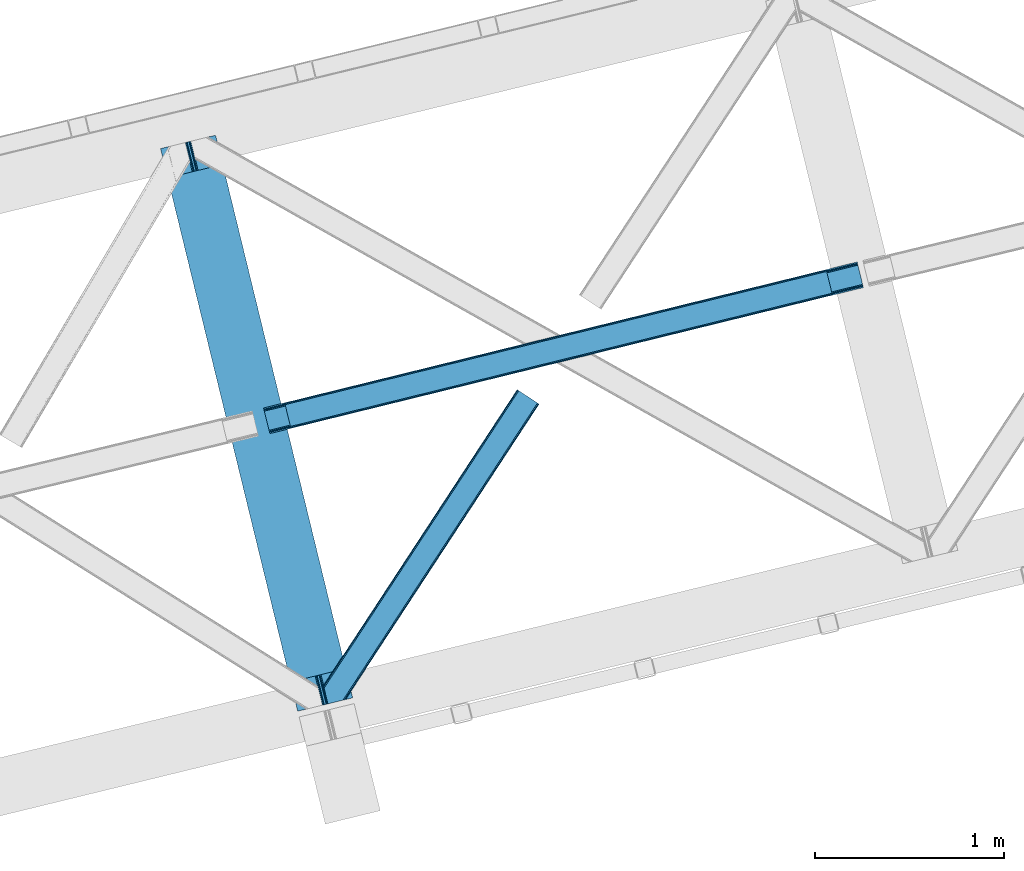
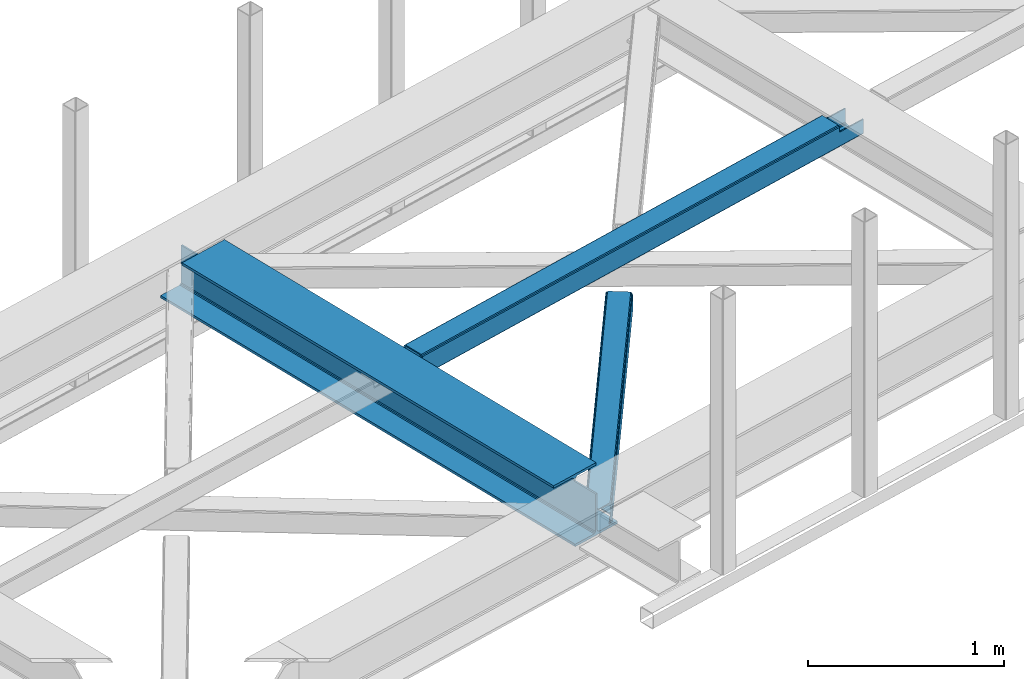
# One storey, part 25 of 66: 2 beams, 1 member.
"""IFC4 building model written with IfcOpenShell, lengths in millimetres."""

import ifcopenshell
import ifcopenshell.guid

model = None  # the IFC model being written
_history = None  # IfcOwnerHistory: only IFC2X3 demands one
_inside = {}  # id of a spatial element -> (the spatial element, [elements in it])
_under = {}  # id of a project, library or spatial element -> (it, [spatial elements below it])
_declared = {}  # id of a project -> (the project, [libraries it declares])
_typed = {}  # id of a type object -> (the type object, [elements of that type])
_made_of = {}  # id of a material, layer set ... -> (it, [elements and type objects made of it])


def new_model(schema):
    """Start an empty IFC model of exactly this schema.

    Asked for "IFC4X3", IfcOpenShell would pick the latest addendum, in which some entities
    have other attributes; the version numbers below select the first issue.
    IFC2X3 requires an IfcOwnerHistory on every rooted entity: one is made here for all.
    """
    global model, _history
    if schema == "IFC4X3":
        model = ifcopenshell.file(schema_version=(4, 3, 0, 0))
    else:
        model = ifcopenshell.file(schema=schema)
    _inside.clear()
    _under.clear()
    _declared.clear()
    _typed.clear()
    _made_of.clear()
    _history = None
    if model.schema == "IFC2X3":
        org = make("IfcOrganization", Name="unknown")
        user = make(
            "IfcPersonAndOrganization",
            ThePerson=make("IfcPerson", FamilyName="unknown"),
            TheOrganization=org,
        )
        app = make(
            "IfcApplication",
            ApplicationDeveloper=org,
            Version="unknown",
            ApplicationFullName="unknown",
            ApplicationIdentifier="unknown",
        )
        _history = make(
            "IfcOwnerHistory",
            OwningUser=user,
            OwningApplication=app,
            ChangeAction="ADDED",
            CreationDate=0,
        )
    return model


def make(cls, **values):
    """One entity of the class cls with the attributes given. An attribute that is None is left unset."""
    return model.create_entity(
        cls, **{name: value for name, value in values.items() if value is not None}
    )


def entity(cls, *values):
    """Any entity or typed value of the class cls, its attributes in the order of the schema. None: left unset."""
    e = model.create_entity(cls)
    for i, value in enumerate(values):
        if value is not None:
            e[i] = value
    return e


def rooted(cls, **values):
    """An entity with a GlobalId (a new one), such as an element, a storey or a relation."""
    return make(cls, GlobalId=ifcopenshell.guid.new(), OwnerHistory=_history, **values)


def si_unit(unit_type, name, prefix=None):
    """IfcSIUnit, for example si_unit("LENGTHUNIT", "METRE", prefix="MILLI")."""
    return make("IfcSIUnit", UnitType=unit_type, Prefix=prefix, Name=name)


def converted_unit(unit_type, name, factor, base, dimensions=None, offset=None):
    """IfcConversionBasedUnit, such as the inch: factor (a typed value) times the base unit."""
    return make(
        "IfcConversionBasedUnit"
        if offset is None
        else "IfcConversionBasedUnitWithOffset",
        ConversionOffset=offset,
        Dimensions=None
        if dimensions is None
        else entity("IfcDimensionalExponents", *dimensions),
        UnitType=unit_type,
        Name=name,
        ConversionFactor=make(
            "IfcMeasureWithUnit", ValueComponent=factor, UnitComponent=base
        ),
    )


def derived_unit(unit_type, elements):
    """IfcDerivedUnit: a product of units, each with its exponent."""
    return make(
        "IfcDerivedUnit",
        Elements=[
            make("IfcDerivedUnitElement", Unit=unit, Exponent=power)
            for unit, power in elements
        ],
        UnitType=unit_type,
    )


def assignment(units):
    """IfcUnitAssignment: the units of a project."""
    return None if units is None else make("IfcUnitAssignment", Units=units)


def point(xyz):
    """IfcCartesianPoint."""
    return None if xyz is None else make("IfcCartesianPoint", Coordinates=xyz)


def direction(xyz):
    """IfcDirection."""
    return None if xyz is None else make("IfcDirection", DirectionRatios=xyz)


def frame(location, z_axis=None, x_axis=None):
    """IfcAxis2Placement3D, a coordinate frame: its origin and axes. An axis left out is left unset."""
    return make(
        "IfcAxis2Placement3D",
        Location=point(location),
        Axis=direction(z_axis),
        RefDirection=direction(x_axis),
    )


def origin():
    """The frame at (0, 0, 0) with its axes left unset."""
    return frame((0.0, 0.0, 0.0))


def place(relative_to, where):
    """IfcLocalPlacement: puts the frame where relative to a parent placement (None: the world)."""
    return make(
        "IfcLocalPlacement", PlacementRelTo=relative_to, RelativePlacement=where
    )


def context(
    kind, dimensions, precision=None, world=None, true_north=None, identifier=None
):
    """IfcGeometricRepresentationContext, for example the 3D "Model" context."""
    return make(
        "IfcGeometricRepresentationContext",
        ContextIdentifier=identifier,
        ContextType=kind,
        CoordinateSpaceDimension=dimensions,
        Precision=precision,
        WorldCoordinateSystem=world,
        TrueNorth=true_north,
    )


def subcontext(parent, identifier, kind, view, scale=None):
    """IfcGeometricRepresentationSubContext, for example "Body" below "Model"."""
    return make(
        "IfcGeometricRepresentationSubContext",
        ContextIdentifier=identifier,
        ContextType=kind,
        ParentContext=parent,
        TargetScale=scale,
        TargetView=view,
    )


def project(units=None, contexts=None):
    """IfcProject with its units and contexts."""
    return rooted(
        "IfcProject",
        Name="project",
        RepresentationContexts=contexts,
        UnitsInContext=assignment(units),
    )


def spatial(cls, under=None, at=None, **own):
    """A site, building, storey or space (cls), placed at a placement, below another one or the project."""
    s = rooted(cls, ObjectPlacement=at, **own)
    if under is not None:
        _under.setdefault(under.id(), (under, []))[1].append(s)
    return s


def point_list(points):
    """IfcCartesianPointList2D or 3D."""
    cls = (
        "IfcCartesianPointList2D" if len(points[0]) == 2 else "IfcCartesianPointList3D"
    )
    return make(cls, CoordList=points)


def triangles(points, corners, closed=None, point_numbers=None):
    """IfcTriangulatedFaceSet: each triangle names its three corners, points numbered from 1."""
    return make(
        "IfcTriangulatedFaceSet",
        Coordinates=point_list(points),
        Closed=closed,
        CoordIndex=corners,
        PnIndex=point_numbers,
    )


def polygons(points, faces, closed=None, point_numbers=None):
    """IfcPolygonalFaceSet: a face is its outer loop, then its inner loops; points numbered from 1."""
    made = []
    for loops in faces:
        if len(loops) == 1:
            made.append(make("IfcIndexedPolygonalFace", CoordIndex=loops[0]))
        else:
            made.append(
                make(
                    "IfcIndexedPolygonalFaceWithVoids",
                    CoordIndex=loops[0],
                    InnerCoordIndices=loops[1:],
                )
            )
    return make(
        "IfcPolygonalFaceSet",
        Coordinates=point_list(points),
        Closed=closed,
        Faces=made,
        PnIndex=point_numbers,
    )


def shape(context_of_items, identifier, shape_type, items):
    """IfcShapeRepresentation: the items that make up one representation, for example the "Body"."""
    return make(
        "IfcShapeRepresentation",
        ContextOfItems=context_of_items,
        RepresentationIdentifier=identifier,
        RepresentationType=shape_type,
        Items=items,
    )


def material(Name=None, Category=None):
    """IfcMaterial."""
    return make("IfcMaterial", Name=Name, Category=Category)


def made_of(thing, what):
    """Note that an element or type object is made of a material, layer set ...; save() writes the relation."""
    if what is not None:
        _made_of.setdefault(what.id(), (what, []))[1].append(thing)
    return thing


def type_object(cls, material=None, **own):
    """A type object (cls), such as IfcWallType, which elements share."""
    return made_of(rooted(cls, **own), material)


def element(
    cls,
    number,
    at=None,
    inside=None,
    cuts=None,
    type_object=None,
    material=None,
    context=None,
    identifier="Body",
    shape_type=None,
    held_by="IfcProductDefinitionShape",
    body=None,
    shapes=None,
    **own,
):
    """One element of the class cls, such as IfcWall. Its Tag is "e" and its number.

    at: its placement. inside: the storey or other place that contains it. cuts: it is an
    opening in that element (IfcRelVoidsElement). A single representation is given by context,
    identifier, shape_type and body (its items); several are given by shapes. held_by: the class
    of the entity that holds the representations. save() writes the other relations.
    """
    e = rooted(cls, Tag="e%d" % number, ObjectPlacement=at, **own)
    if body is not None:
        shapes = [shape(context, identifier, shape_type, body)]
    if shapes is not None:
        e.Representation = make(held_by, Representations=shapes)
    if inside is not None:
        _inside.setdefault(inside.id(), (inside, []))[1].append(e)
    if cuts is not None:
        rooted(
            "IfcRelVoidsElement", RelatingBuildingElement=cuts, RelatedOpeningElement=e
        )
    if type_object is not None:
        _typed.setdefault(type_object.id(), (type_object, []))[1].append(e)
    return made_of(e, material)


def aggregate(whole, parts):
    """IfcRelAggregates: a whole, such as a stair, and the parts it consists of."""
    return rooted("IfcRelAggregates", RelatingObject=whole, RelatedObjects=parts)


def save(model, path):
    """Write the relations noted so far, then the file.

    IfcRelAggregates (storeys below a building ...), IfcRelContainedInSpatialStructure (elements
    in a storey), IfcRelDefinesByType, IfcRelAssociatesMaterial and IfcRelDeclares: one each for
    every whole, place, type object, material and project.
    """
    for whole, parts in _under.values():
        aggregate(whole, parts)
    for where, things in _inside.values():
        rooted(
            "IfcRelContainedInSpatialStructure",
            RelatedElements=things,
            RelatingStructure=where,
        )
    for kind, things in _typed.values():
        rooted("IfcRelDefinesByType", RelatedObjects=things, RelatingType=kind)
    for what, things in _made_of.values():
        rooted("IfcRelAssociatesMaterial", RelatedObjects=things, RelatingMaterial=what)
    for by, libraries in _declared.values():
        rooted("IfcRelDeclares", RelatingContext=by, RelatedDefinitions=libraries)
    model.write(path)


model = new_model("IFC4")

# Units and contexts
model_context = context("Model", 3, precision=0.01, world=origin(), true_north=direction((6.12303176911189e-17, 1.0)))
plan_context = context("Plan", 3, precision=0.01, world=origin(), true_north=direction((6.12303176911189e-17, 1.0)))
body_context = subcontext(model_context, "Body", "Model", "MODEL_VIEW")
ifc_project = project(units=[si_unit("LENGTHUNIT", "METRE", prefix="MILLI"), si_unit("AREAUNIT", "SQUARE_METRE"), si_unit("VOLUMEUNIT", "CUBIC_METRE"), converted_unit("PLANEANGLEUNIT", "DEGREE", entity("IfcRatioMeasure", 0.0174532925199433), si_unit("PLANEANGLEUNIT", "RADIAN"), dimensions=[0, 0, 0, 0, 0, 0, 0]), si_unit("MASSUNIT", "GRAM", prefix="KILO"), derived_unit("MASSDENSITYUNIT", [(si_unit("MASSUNIT", "GRAM", prefix="KILO"), 1), (si_unit("LENGTHUNIT", "METRE"), -3)]), derived_unit("MOMENTOFINERTIAUNIT", [(si_unit("LENGTHUNIT", "METRE"), 4)]), si_unit("TIMEUNIT", "SECOND"), si_unit("FREQUENCYUNIT", "HERTZ"), si_unit("THERMODYNAMICTEMPERATUREUNIT", "DEGREE_CELSIUS"), derived_unit("THERMALTRANSMITTANCEUNIT", [(si_unit("MASSUNIT", "GRAM", prefix="KILO"), 1), (si_unit("THERMODYNAMICTEMPERATUREUNIT", "KELVIN"), -1), (si_unit("TIMEUNIT", "SECOND"), -3)]), derived_unit("VOLUMETRICFLOWRATEUNIT", [(si_unit("LENGTHUNIT", "METRE"), 3), (si_unit("TIMEUNIT", "SECOND"), -1)]), derived_unit("MASSFLOWRATEUNIT", [(si_unit("MASSUNIT", "GRAM", prefix="KILO"), 1), (si_unit("TIMEUNIT", "SECOND"), -1)]), derived_unit("ROTATIONALFREQUENCYUNIT", [(si_unit("TIMEUNIT", "SECOND"), -1)]), si_unit("ELECTRICCURRENTUNIT", "AMPERE"), si_unit("ELECTRICVOLTAGEUNIT", "VOLT"), si_unit("POWERUNIT", "WATT"), si_unit("FORCEUNIT", "NEWTON", prefix="KILO"), si_unit("ILLUMINANCEUNIT", "LUX"), si_unit("LUMINOUSFLUXUNIT", "LUMEN"), si_unit("LUMINOUSINTENSITYUNIT", "CANDELA"), derived_unit("USERDEFINED", [(si_unit("MASSUNIT", "GRAM", prefix="KILO"), -1), (si_unit("LENGTHUNIT", "METRE"), -2), (si_unit("TIMEUNIT", "SECOND"), 3), (si_unit("LUMINOUSFLUXUNIT", "LUMEN"), 1)]), derived_unit("LINEARVELOCITYUNIT", [(si_unit("LENGTHUNIT", "METRE"), 1), (si_unit("TIMEUNIT", "SECOND"), -1)]), si_unit("PRESSUREUNIT", "PASCAL"), derived_unit("USERDEFINED", [(si_unit("LENGTHUNIT", "METRE"), -2), (si_unit("MASSUNIT", "GRAM", prefix="KILO"), 1), (si_unit("TIMEUNIT", "SECOND"), -2)]), derived_unit("LINEARFORCEUNIT", [(si_unit("MASSUNIT", "GRAM", prefix="KILO"), 1), (si_unit("LENGTHUNIT", "METRE"), 1), (si_unit("TIMEUNIT", "SECOND"), -2), (si_unit("LENGTHUNIT", "METRE"), -1)]), derived_unit("PLANARFORCEUNIT", [(si_unit("MASSUNIT", "GRAM", prefix="KILO"), 1), (si_unit("LENGTHUNIT", "METRE"), 1), (si_unit("TIMEUNIT", "SECOND"), -2), (si_unit("LENGTHUNIT", "METRE"), -2)])], contexts=[model_context, plan_context])

# Site, building, storey
site_placement = place(None, origin())
site = spatial("IfcSite", under=ifc_project, at=site_placement, CompositionType="ELEMENT")
building_placement = place(site_placement, origin())
building = spatial("IfcBuilding", under=site, at=building_placement, CompositionType="ELEMENT")
storey_placement = place(building_placement, frame((0.0, 0.0, 19800.0)))
storey = spatial("IfcBuildingStorey", under=building, at=storey_placement, Name="06", CompositionType="ELEMENT", Elevation=19800.0)

# Beams
ifc_material = material(Name="Metal painted (White)")
beam_type = type_object("IfcBeamType", PredefinedType="BEAM")
beam_1_placement = place(storey_placement, frame((-49493.18, 5730.44, 3808.0)))
element("IfcBeam", 1, at=beam_1_placement, inside=storey, type_object=beam_type, material=ifc_material, ObjectType="Steel Beam", PredefinedType="BEAM", context=body_context, shape_type="Tessellation", body=[
    polygons([(1018.16648378331, 71.0478278971021, 15.5000000000051), (1018.16648378331, 71.0478278971021, 0.0), (291.465617442455, 3052.25531830421, 0.0), (291.465617442464, 3052.25531830421, 15.5000000000051), (894.779372399346, 40.9709140873291, 15.5000000000051), (168.078506058491, 3022.17840449444, 15.5000000000051), (888.087028625375, 39.3395844888232, 16.8701684148028), (161.386162284528, 3020.54707489594, 16.8701684148028), (882.413533524759, 37.9566100336519, 20.7720779386478), (155.712667183921, 3019.16410044076, 20.7720779386478), (878.622625296184, 37.0325360459173, 26.6116982174338), (151.921758955338, 3018.24002645303, 26.6116982174338), (877.291435352796, 36.7080444135029, 33.500000000001), (150.590569011932, 3017.91553482062, 33.500000000001), (140.875048430522, 3015.54727389071, 33.500000000001), (140.875048430531, 3015.54727389071, 259.000000000006), (150.590569011932, 3017.91553482062, 259.000000000006), (0.0, 2981.20749040711, 4.33146851719357e-12), (8.66293703438714e-12, 2981.20749040711, 15.5000000000051), (123.387111383972, 3011.28440421688, 15.5000000000051), (130.079455157926, 3012.91573381539, 16.8701684148028), (135.752950258551, 3014.29870827056, 20.7720779386478), (139.543858487126, 3015.2227822583, 26.6116982174338), (877.291435352788, 36.7080444135029, 259.000000000006), (867.575914771378, 34.3397834835992, 259.000000000006), (867.575914771378, 34.3397834836003, 33.500000000001), (866.244724827981, 34.0152918511837, 26.6116982174338), (862.453816599406, 33.0912178634492, 20.7720779386478), (856.780321498782, 31.7082434082778, 16.8701684148028), (850.087977724828, 30.076913809773, 15.5000000000051), (726.700866340855, 0.0, 15.5000000000051), (726.700866340855, 0.0, 4.33146851719357e-12), (839.723099725422, 190.827961666227, 259.069792599954), (188.068298227665, 2864.16742161973, 259.000000000006), (188.291691329505, 2863.25097721476, 259.617303331129), (188.304080173139, 2863.20015298098, 266.500003008253), (839.577920935832, 191.42343960925, 266.500002998871), (839.578271056585, 191.422003304516, 260.000004007593), (830.09816248951, 188.087889491627, 259.00634317046), (829.874792453813, 189.004341089457, 259.617303331129), (829.862403610171, 189.055165323231, 266.500003008253), (178.588562847478, 2860.83187869496, 266.500002998871), (178.588212726726, 2860.8333149997, 260.000004007593), (178.44340706839, 2861.42736381349, 259.076120467494), (178.352777646246, 2861.79916068982, 259.000000000006), (840.90940880576, 191.746709053934, 273.388305639792), (844.699685394456, 192.673374225848, 279.227924098781), (850.372756341994, 194.058088689525, 283.129832400619), (857.064948023119, 195.690042220338, 284.500000377228), (980.451976710963, 225.767295275449, 284.500000138975), (980.450306904311, 225.774145344181, 299.999995328161), (688.984884807032, 154.725516080138, 299.999995890966), (688.986554613684, 154.718666011407, 284.500000701776), (812.373583301537, 184.795919066518, 284.500000463524), (819.066070197675, 186.426661533096, 283.129832461069), (824.739981846436, 187.807927177622, 279.227924137327), (828.531516633427, 188.72943082692, 273.388305663689), (177.257074977542, 2860.50860925028, 273.388305639792), (173.466798388855, 2859.58194407836, 279.227924098781), (167.793727441316, 2858.19722961469, 283.129832400619), (161.101535760191, 2856.56527608387, 284.500000377228), (37.7145070723384, 2826.48802302876, 284.500000138975), (37.7161768790075, 2826.48117296003, 299.999995328161), (329.181598976278, 2897.52980222407, 299.999995890962), (329.179929169617, 2897.53665229281, 284.500000701776), (205.792900481773, 2867.4593992377, 284.500000463524), (199.100413585635, 2865.82865677112, 283.129832461069), (193.426501936874, 2864.44739112659, 279.227924137327), (189.634967149883, 2863.52588747729, 273.388305663689)], [[[1, 2, 3, 4]], [[5, 1, 4, 6]], [[7, 5, 6, 8]], [[9, 7, 8, 10]], [[11, 9, 10, 12]], [[13, 11, 12, 14]], [[15, 16, 17, 14, 12, 10, 8, 6, 4, 3, 18, 19, 20, 21, 22, 23]], [[13, 24, 25, 26, 27, 28, 29, 30, 31, 32, 2, 1, 5, 7, 9, 11]], [[2, 32, 18, 3]], [[32, 31, 19, 18]], [[31, 30, 20, 19]], [[27, 26, 15, 23]], [[28, 27, 23, 22]], [[29, 28, 22, 21]], [[30, 29, 21, 20]], [[33, 24, 13, 14, 17, 34, 35, 36, 37, 38]], [[25, 39, 40, 41, 42, 43, 44, 16, 15, 26]], [[39, 25, 24, 33]], [[45, 34, 17, 16]], [[41, 40, 38, 37, 46, 47, 48, 49, 50, 51, 52, 53, 54, 55, 56, 57]], [[42, 58, 59, 60, 61, 62, 63, 64, 65, 66, 67, 68, 69, 36, 35, 43]], [[46, 37, 36, 69]], [[47, 46, 69, 68]], [[48, 47, 68, 67]], [[49, 48, 67, 66]], [[50, 49, 66, 65]], [[51, 50, 65, 64]], [[52, 51, 64, 63]], [[53, 52, 63, 62]], [[54, 53, 62, 61]], [[55, 54, 61, 60]], [[56, 55, 60, 59]], [[57, 56, 59, 58]], [[41, 57, 58, 42]]], closed=False),
])
beam_2_placement = place(storey_placement, frame((-48947.6, 7201.57, 3967.02)))
element("IfcBeam", 2, at=beam_2_placement, inside=storey, type_object=beam_type, material=ifc_material, ObjectType="Steel Beam", PredefinedType="BEAM", context=body_context, shape_type="Tessellation", body=[
    polygons([(3014.66198685415, 733.277520458038, 122.551106515378), (3014.34650819573, 734.571735702759, 129.24806605045), (144.865809052569, 28.7790637903131, 130.140231320828), (145.18128771098, 27.4848485456453, 123.443271785764), (3013.44810098643, 738.257348897747, 134.92547253129), (143.967401843277, 32.4646769852602, 135.817637801681), (3012.10353957978, 743.773258844291, 138.718992287022), (142.622840436624, 37.9805869318079, 139.611157557409), (3010.51752126149, 750.279718254773, 140.051096323177), (141.036822118309, 44.4870463424154, 140.943261593568), (2985.65072770548, 852.292905035273, 140.051030384396), (116.1700285623, 146.50023312292, 140.943195654778), (2984.06470938713, 858.79936444598, 138.71891793701), (114.584010243976, 153.006692533531, 139.611083207401), (2982.72014798048, 864.315274392527, 134.92539105058), (113.239448837332, 158.522602480079, 135.817556320971), (2981.8217407712, 868.000887587489, 129.247979805159), (112.341041628031, 162.208215675055, 130.14014507555), (2981.50626211281, 869.295102832038, 122.551018597005), (112.025562969637, 163.502430919657, 123.443183867375), (113.683357408731, 156.701518153041, 116.478003953074), (113.998827865116, 155.407336556291, 123.140149152425), (114.897235074409, 151.721723361319, 128.817560397855), (116.241796481061, 146.205813414771, 132.611087284285), (117.827814799368, 139.699354004221, 133.943199731657), (139.37903588124, 51.2879254611191, 133.943256878606), (140.965054199582, 44.7814660504163, 132.611152842451), (142.309615606234, 39.2655561038664, 128.817633086723), (143.208022815527, 35.5799429088976, 123.140226605874), (143.523493309154, 34.2857611593384, 116.478003953074), (145.18128771098, 27.4848485456616, 116.47800395307), (112.025562969637, 163.502430919668, 116.47800395307), (2981.50626211281, 869.295102832025, 100.498227844497), (3014.66198685415, 733.277520458023, 100.498227844497), (3013.00420052616, 740.078399946393, 100.498227844497), (3013.00420061709, 740.078399576723, 115.551101800424), (3012.68872195868, 741.372614821346, 122.248061335492), (3011.79031474938, 745.058228016315, 127.925467816341), (3010.44575334274, 750.574137962861, 131.718987572073), (3008.85973502442, 757.080597373472, 133.051091608228), (2987.30851394254, 845.492025916574, 133.051034461284), (2985.72249562422, 851.998485327185, 131.718922013898), (2984.37793421758, 857.514395273731, 127.925395127473), (2983.47952700828, 861.200008468702, 122.247983882047), (2983.16404849861, 862.494223108653, 115.551022673885), (2983.16404834987, 862.494223713326, 100.498227844497), (143.616995693866, 27.1000869952791, 112.588916656551), (142.052703676727, 26.7153254450113, 108.699829360001), (138.276168673461, 25.7864288919117, 107.08891665653), (134.499633670186, 24.857532338875, 105.478003953059), (33.4640040774262, 0.0062737156981143, 105.478003953085), (33.4384975699194, 9.74580416368554e-12, 18.478009536212), (3178.77103529923, 773.642651271288, 17.5000777261801), (3178.77103529923, 773.642651271288, 99.498227844506), (3015.63304631242, 733.516367385914, 99.4982278445016), (8.66293703438714e-12, 135.948030071304, 18.478009536212), (0.0255065074981076, 135.95430378699, 105.478003953085), (101.343908928827, 160.875114712881, 105.478003953085), (105.12044393211, 161.804011265932, 107.088916656556), (108.896978935376, 162.732907819021, 108.699829360019), (110.461270952515, 163.117669369314, 112.588916656546), (3145.61531055789, 909.660233645289, 99.4982278445016), (3145.6153105579, 909.660233645289, 17.4999898077994), (136.618382436393, 32.5873080105591, 107.088916656582), (132.841847009942, 31.6584131779827, 105.478003953103), (140.394917439667, 33.5162045636273, 108.69982936004), (141.96566168455, 33.9025531380652, 112.587584068376), (112.125526157786, 156.318372488323, 112.587581008938), (110.554765172462, 155.93202870027, 108.699829360001), (106.778230169196, 155.003132147206, 107.088916656504), (103.001695695356, 154.074233441606, 105.478003953051), (31.7920783309542, 6.8036787481157, 105.478003953085), (3177.11324895927, 780.443530808336, 99.498227844506), (3177.11324963609, 780.44352805663, 24.5000736492964), (31.7686248297565, 6.79790673020325, 25.4780092171761), (1.69743247226747, 129.156897867046, 105.478003953085), (1.67397729591764, 129.151132659746, 25.4780092171761), (3147.27309610399, 902.859357335771, 24.4999945227572), (3147.27309696331, 902.85935384209, 99.498227844506), (2984.13510802055, 862.733069777618, 99.4982278444973), (3013.97526007535, 740.317246504614, 99.498227844506), (2982.47732157107, 869.533949759916, 99.4982278445016), (3147.58857545337, 901.565139281965, 17.8030349876851), (3148.48698266265, 897.879526086999, 12.125628506845), (3149.8315440693, 892.363616140453, 8.33210875111238), (3151.41756238762, 885.857156729842, 7.00000471495782), (3172.96878346949, 797.445728186741, 7.00006186190616), (3174.55480178782, 790.93926877613, 8.33217430928745), (3175.89936319447, 785.423358829583, 12.1257011957087), (3176.79777040376, 781.737745634615, 17.8031124411339), (3178.45555664086, 774.936866515781, 10.8031165180479), (3177.55714943157, 778.622479710752, 5.12570527262277), (3176.21258802492, 784.1383896573, 1.33217838619282), (3174.62656970656, 790.644849068041, 6.59387855421301e-05), (3149.75977615055, 892.658035848542, 4.33146851719357e-12), (3148.17375783225, 899.164495259058, 1.33210403618054), (3146.82919642561, 904.680405205607, 5.12562379191745), (3145.93078921631, 908.366018400585, 10.8030302727576), (31.4484922777377, 8.09097680671073, 18.78104945601), (30.5407583952027, 11.7742959637272, 13.1036411103947), (29.1836175465794, 17.2871118040927, 9.31011813510754), (27.5836821235256, 23.7901480899073, 7.97801001476801), (4.24950437033222, 118.659596043167, 9.31011813510754), (5.84865870308149, 112.156367636244, 7.97801001476368), (2.89458787866886, 124.172958998151, 13.1036411103947), (1.99018298160754, 127.857096970068, 18.78104945601), (0.316205855336193, 134.653993691895, 11.7810497750459), (1.22061075240617, 130.969855719986, 6.10364142943058), (2.57552724406953, 125.456492764999, 2.31011845414345), (4.17468157681881, 118.953264358077, 0.97801033379958), (29.2535547542584, 16.992241804612, 0.978010333803911), (30.8534901773035, 10.4892055187962, 2.31011845414345), (32.2106310259441, 4.97638967843289, 6.10364142943058), (33.1183649084791, 1.29307052141644, 11.7810497750415)], [[[1, 2, 3, 4]], [[2, 5, 6, 3]], [[5, 7, 8, 6]], [[7, 9, 10, 8]], [[11, 12, 10, 9]], [[11, 13, 14, 12]], [[13, 15, 16, 14]], [[15, 17, 18, 16]], [[17, 19, 20, 18]], [[21, 22, 23, 24, 25, 26, 27, 28, 29, 30, 31, 4, 3, 6, 8, 10, 12, 14, 16, 18, 20, 32]], [[33, 19, 17, 15, 13, 11, 9, 7, 5, 2, 1, 34, 35, 36, 37, 38, 39, 40, 41, 42, 43, 44, 45, 46]], [[26, 25, 41, 40]], [[40, 39, 27, 26]], [[39, 38, 28, 27]], [[38, 37, 29, 28]], [[37, 30, 29]], [[36, 30, 37]], [[25, 24, 42, 41]], [[24, 23, 43, 42]], [[23, 22, 44, 43]], [[44, 21, 45]], [[21, 44, 22]], [[47, 48, 49, 50, 51, 52, 53, 54, 55, 1, 4, 31]], [[56, 57, 58, 59, 60, 61, 32, 20, 19, 33, 62, 63]], [[50, 49, 64, 65]], [[49, 48, 66, 64]], [[66, 47, 67]], [[47, 30, 67]], [[30, 47, 31]], [[47, 66, 48]], [[68, 60, 69]], [[60, 59, 70, 69]], [[59, 58, 71, 70]], [[60, 68, 61]], [[61, 21, 32]], [[21, 61, 68]], [[72, 65, 64, 66, 67, 30, 36, 35, 73, 74, 75]], [[71, 76, 77, 78, 79, 80, 45, 21, 68, 69, 70]], [[55, 54, 73, 81]], [[62, 82, 80, 79]], [[63, 62, 79, 78, 83, 84, 85, 86, 87, 88, 89, 90, 74, 73, 54, 53, 91, 92, 93, 94, 95, 96, 97, 98]], [[57, 76, 71, 58]], [[50, 65, 72, 51]], [[74, 90, 99, 75]], [[90, 89, 100, 99]], [[89, 88, 101, 100]], [[88, 87, 102, 101]], [[86, 85, 103, 104]], [[85, 84, 105, 103]], [[84, 83, 106, 105]], [[83, 78, 77, 106]], [[102, 87, 86, 104]], [[52, 51, 72, 75, 99, 100, 101, 102, 104, 103, 105, 106, 77, 76, 57, 56, 107, 108, 109, 110, 111, 112, 113, 114]], [[94, 93, 112, 111]], [[93, 92, 113, 112]], [[92, 91, 114, 113]], [[91, 53, 52, 114]], [[63, 98, 107, 56]], [[98, 97, 108, 107]], [[97, 96, 109, 108]], [[96, 95, 110, 109]], [[95, 94, 111, 110]]], closed=False),
])

# Member
member_type = type_object("IfcMemberType", PredefinedType="BRACE")
member_placement = place(storey_placement, frame((-48630.06, 5769.52, 3824.0)))
element("IfcMember", 3, at=member_placement, inside=storey, type_object=member_type, ObjectType="Steel Horizontal Brace", PredefinedType="BRACE", context=body_context, shape_type="Tessellation", body=[
    triangles([(109.770043945311, 259.949830627442, 7.52047119140843), (115.030187988275, 238.365682983398, 7.77626953125218), (114.216284179682, 239.94640045166, 8.3320495605476), (108.807312011719, 259.662057495118, 8.52041015625218), (113.6349243164, 239.859777832031, 8.52041015625218), (112.207104492183, 237.677352905273, 8.52041015625218), (91.0363037109346, 232.516621398926, 8.52041015625218), (109.532849121089, 237.025648498535, 9.49942016601563), (90.2596069335923, 232.32767944336, 9.49942016601563), (5.01829833984084, 77.405158996582, 9.49942016601563), (0.62786865234375, 95.4308029174808, 9.49942016601563), (1046.62448730468, 1651.75324859619, 6.99957275390625), (1041.02017822265, 1655.42221069336, 8.3320495605476), (116.699853515624, 231.514356994629, 6.99957275390625), (1036.27163085937, 1658.53190460205, 12.1248413085959), (3.92999267578125, 81.8752349853512, 12.1248413085959), (1033.0950805664, 1660.61026611328, 17.8035644531265), (2.70216064452688, 86.9220199584961, 17.8035644531265), (1031.98352050781, 1661.3398727417, 24.5008300781265), (2.26962890624418, 88.6940048217775, 24.5008300781265), (1122.75472412109, 1601.90454711914, 6.99957275390625), (146.20968017578, 110.458955383301, 6.99957275390625), (1031.98352050781, 1661.3398727417, 115.499926757813), (2.26962890624418, 88.6940048217775, 115.499926757813), (1033.0950805664, 1660.61026611328, 122.197192382813), (2.70216064452688, 86.9220199584961, 122.197192382813), (1036.27163085937, 1658.53190460205, 127.873590087893), (3.92999267578125, 81.8752349853512, 127.873590087893), (1041.02017822265, 1655.42221069336, 131.668707275392), (5.77174072265188, 74.322789001465, 131.668707275392), (1046.62448730468, 1651.75324859619, 133.001184082033), (7.94370117186918, 65.4140304565426, 133.001184082033), (1027.23962402344, 1664.44433441162, 10.8039916992202), (0.520898437498545, 95.8714736938473, 10.8691040039084), (0.0, 98.0056457519531, 17.5012573242202), (1035.16472167968, 1659.2562789917, 1.33247680664135), (112.258264160155, 249.73533782959, 1.33247680664135), (110.542089843744, 256.771536254882, 5.59500732422021), (109.077062988275, 259.839372253418, 8.32042236328198), (1030.4161743164, 1662.36655426025, 5.12526855468968), (1040.76903076172, 1655.58789825439, 0.0), (114.430224609372, 240.826579284668, 0.0), (1026.12806396484, 1665.1745223999, 17.5012573242202), (1128.61018066406, 1598.06989746094, 0.0), (148.479309082031, 101.147314453125, 0.0), (150.651269531249, 92.2385559082031, 1.33247680664135), (148.507214355464, 101.029298400879, 8.49948120117188), (152.488366699217, 84.686109924316, 5.12526855468968), (153.344128417964, 81.1822540283201, 8.49948120117188), (1026.12806396484, 1665.1745223999, 122.499499511719), (0.0, 98.0056457519531, 122.499499511719), (1040.76903076172, 1655.58789825439, 140.00075683594), (1035.16472167968, 1659.2562789917, 138.668280029298), (3.50211181640043, 83.6350112915043, 138.668280029298), (5.674072265625, 74.7262527465818, 140.00075683594), (1030.4161743164, 1662.36655426025, 134.87548828125), (1.66036376952979, 91.1874572753904, 134.87548828125), (1027.23962402344, 1664.44433441162, 129.196765136719), (0.432531738275429, 96.2336608886717, 129.196765136719), (23.8869140624956, 0.0, 140.00075683594), (23.8869140624956, 0.0, 133.001184082033), (1128.61018066406, 1598.06989746094, 140.00075683594), (93.3338378906192, 16.9280364990236, 140.00075683594), (1122.75472412109, 1601.90454711914, 133.001184082033), (83.3763061523423, 14.5008590698244, 133.001184082033), (1143.25114746093, 1588.48385467529, 122.499499511719), (1142.13958740234, 1589.21346130371, 129.196765136719), (118.225341796875, 22.9951080322262, 122.499499511719), (116.327783203124, 22.5335083007813, 129.196765136719), (1138.96303710937, 1591.29182281494, 134.87548828125), (110.932763671874, 21.2184722900392, 134.87548828125), (1134.21448974609, 1594.4020980835, 138.668280029298), (102.858837890621, 19.2499877929686, 138.668280029298), (1143.25114746093, 1588.48385467529, 17.5012573242202), (118.225341796875, 22.9951080322262, 17.5012573242202), (1142.13958740234, 1589.21346130371, 10.8039916992202), (1133.1075805664, 1595.12647247314, 12.1248413085959), (1136.27947998047, 1593.04811096191, 17.8035644531265), (1137.39569091797, 1592.3185043335, 24.5008300781265), (1138.96303710937, 1591.29182281494, 5.12526855468968), (1134.21448974609, 1594.4020980835, 1.33247680664135), (1128.35903320312, 1598.23616638184, 8.3320495605476), (1133.1075805664, 1595.12647247314, 127.873590087893), (1137.39569091797, 1592.3185043335, 115.499926757813), (1136.27947998047, 1593.04811096191, 122.197192382813), (1128.35903320312, 1598.23616638184, 131.668707275392), (92.9013061523438, 16.8228103637693, 131.668707275392), (100.979882812499, 18.79129486084, 127.873590087893), (106.374902343749, 20.106330871582, 122.197192382813), (108.267810058591, 20.5685119628906, 115.499926757813), (108.267810058591, 20.5685119628906, 24.5008300781265), (100.979882812499, 18.79129486084, 12.1248413085959), (115.472021484369, 22.32421875, 9.49942016601563), (106.374902343749, 20.106330871582, 17.8035644531265), (96.1987792968721, 17.6262496948239, 9.49942016601563), (115.941760253903, 22.4393280029299, 10.8691040039084), (153.060424804688, 80.2392883300781, 8.99945068359375), (152.776721191403, 79.2969039916989, 9.49942016601563), (148.711853027344, 99.8677413940432, 8.8831787109375), (148.600231933589, 99.023606872559, 9.08781738281323), (148.493261718744, 98.1672637939455, 9.2947814941399), (148.381640624997, 97.3225479125977, 9.49942016601563)], [[1, 2, 3], [4, 5, 6], [6, 7, 4], [7, 6, 8], [8, 9, 7], [9, 8, 10], [10, 11, 9], [12, 13, 3], [3, 2, 12], [2, 14, 12], [15, 16, 8], [8, 13, 15], [8, 5, 13], [16, 10, 8], [8, 6, 5], [15, 17, 18], [18, 16, 15], [17, 19, 20], [20, 18, 17], [21, 12, 14], [14, 22, 21], [19, 23, 20], [24, 20, 23], [23, 25, 24], [26, 24, 25], [25, 27, 26], [28, 26, 27], [27, 29, 28], [30, 28, 29], [29, 31, 30], [32, 30, 31], [33, 34, 35], [36, 37, 38], [33, 4, 9], [33, 1, 39], [9, 34, 33], [9, 11, 34], [4, 7, 9], [40, 38, 1], [1, 33, 40], [38, 40, 36], [36, 41, 37], [42, 37, 41], [35, 43, 33], [41, 44, 42], [45, 42, 44], [14, 42, 22], [37, 2, 38], [2, 37, 42], [38, 2, 1], [42, 14, 2], [22, 42, 45], [46, 47, 45], [47, 46, 48], [45, 47, 22], [48, 49, 47], [50, 43, 51], [35, 51, 43], [52, 53, 54], [54, 55, 52], [53, 56, 57], [57, 54, 53], [56, 58, 59], [59, 57, 56], [58, 50, 51], [51, 59, 58], [28, 57, 26], [30, 32, 55], [32, 60, 55], [32, 61, 60], [54, 30, 55], [28, 54, 57], [16, 11, 10], [28, 30, 54], [51, 35, 20], [24, 26, 51], [24, 51, 20], [57, 59, 26], [26, 59, 51], [35, 18, 20], [18, 11, 16], [11, 18, 34], [35, 34, 18], [62, 55, 63], [62, 52, 55], [55, 60, 63], [64, 32, 31], [32, 64, 65], [61, 32, 65], [66, 67, 68], [69, 68, 67], [67, 70, 69], [71, 69, 70], [70, 72, 71], [73, 71, 72], [72, 62, 73], [63, 73, 62], [74, 66, 75], [68, 75, 66], [76, 77, 78], [79, 66, 74], [76, 78, 74], [76, 80, 77], [78, 79, 74], [77, 80, 81], [21, 44, 41], [44, 82, 81], [82, 44, 21], [82, 77, 81], [67, 83, 70], [84, 66, 79], [66, 85, 67], [85, 66, 84], [67, 85, 83], [62, 64, 52], [72, 70, 83], [83, 86, 72], [86, 64, 62], [62, 72, 86], [15, 36, 40], [41, 12, 21], [41, 13, 12], [13, 41, 36], [15, 13, 36], [19, 43, 50], [33, 17, 15], [40, 33, 15], [17, 33, 43], [19, 17, 43], [53, 27, 56], [52, 64, 31], [31, 29, 52], [29, 27, 53], [53, 52, 29], [58, 56, 27], [50, 23, 19], [25, 50, 58], [50, 25, 23], [25, 58, 27], [64, 86, 87], [87, 65, 64], [86, 83, 88], [88, 87, 86], [83, 85, 89], [89, 88, 83], [85, 84, 90], [90, 89, 85], [84, 79, 90], [91, 90, 79], [89, 68, 69], [87, 73, 63], [60, 65, 63], [65, 60, 61], [65, 87, 63], [88, 73, 87], [88, 89, 71], [71, 73, 88], [69, 71, 89], [91, 75, 68], [92, 93, 94], [89, 90, 68], [92, 95, 93], [91, 94, 75], [90, 91, 68], [96, 75, 94], [94, 93, 96], [76, 74, 75], [49, 80, 97], [98, 97, 80], [49, 48, 80], [76, 96, 98], [98, 80, 76], [96, 93, 98], [44, 81, 45], [46, 45, 81], [81, 80, 46], [48, 46, 80], [75, 96, 76], [82, 21, 22], [77, 82, 47], [47, 99, 77], [77, 100, 101], [100, 77, 99], [101, 102, 77], [77, 102, 92], [95, 92, 102], [22, 47, 82], [79, 78, 91], [94, 91, 78], [78, 77, 94], [92, 94, 77], [102, 101, 98], [101, 100, 97], [100, 99, 49], [99, 47, 49], [102, 98, 93], [93, 95, 102]]),
])

save(model, "model.ifc")
